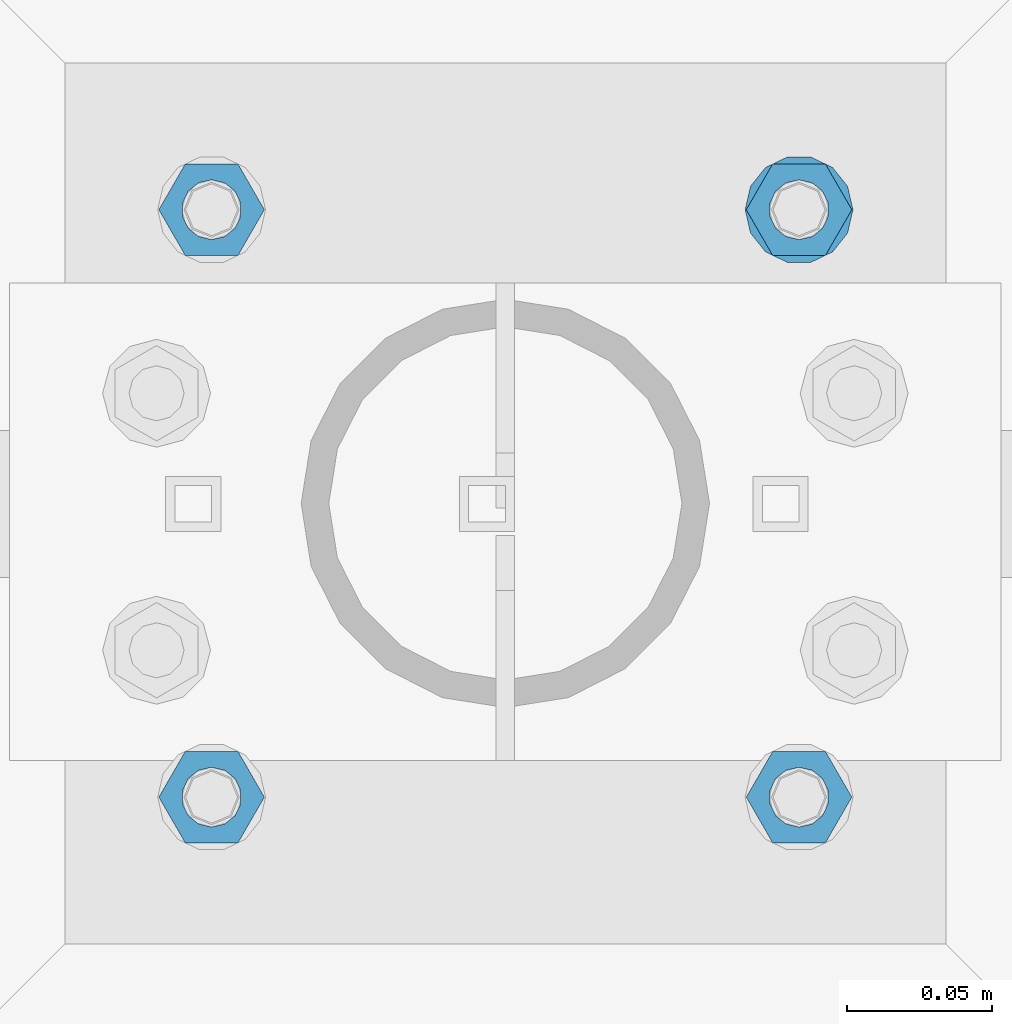
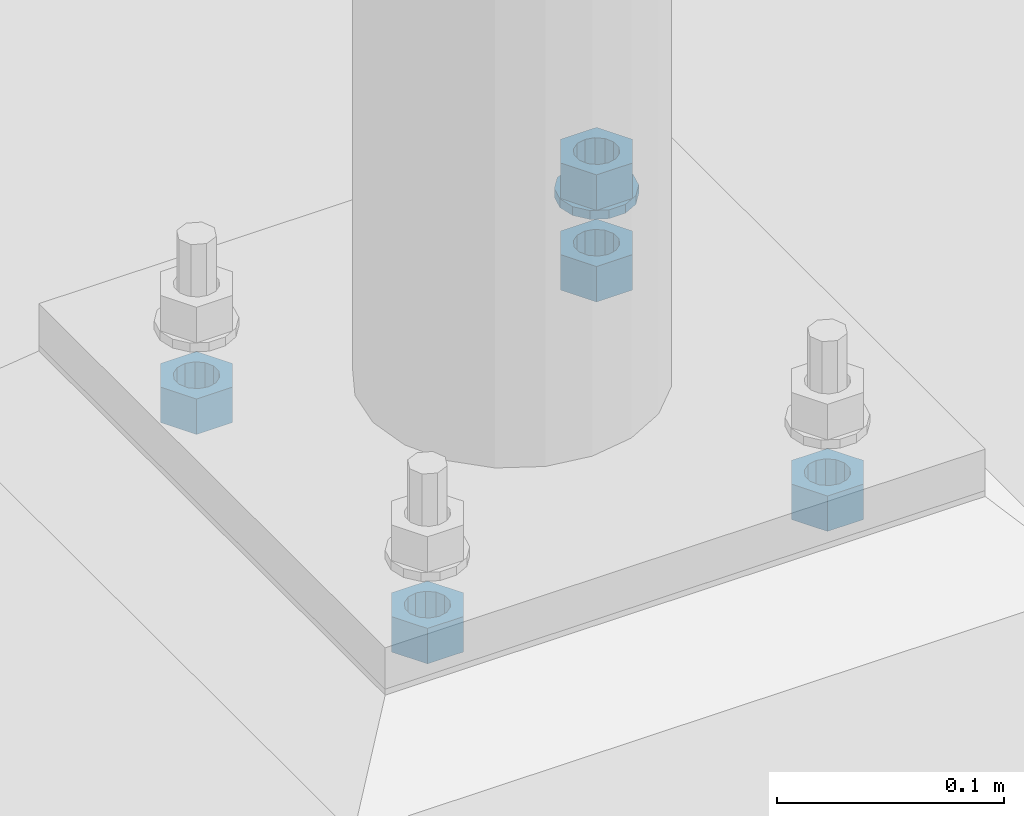
# One storey, part 619 of 975: 6 beams.
"""IFC2X3 building model written with IfcOpenShell, lengths in millimetres."""

from ifc_helpers import new_model, si_unit, frame, origin_with_axes, place, context, subcontext, project, spatial, faceted_brep, material, type_object, element, save


model = new_model("IFC2X3")

# Units and contexts
model_context = context("Model", 3, precision=1e-05, world=origin_with_axes())
body_context = subcontext(model_context, "Body", "Model", "MODEL_VIEW")
ifc_project = project(units=[si_unit("LENGTHUNIT", "METRE", prefix="MILLI"), si_unit("AREAUNIT", "SQUARE_METRE"), si_unit("VOLUMEUNIT", "CUBIC_METRE"), si_unit("MASSUNIT", "GRAM", prefix="KILO"), si_unit("TIMEUNIT", "SECOND"), si_unit("PLANEANGLEUNIT", "RADIAN"), si_unit("SOLIDANGLEUNIT", "STERADIAN"), si_unit("THERMODYNAMICTEMPERATUREUNIT", "DEGREE_CELSIUS"), si_unit("LUMINOUSINTENSITYUNIT", "LUMEN")], contexts=[model_context])

# Site, building, storey
site_placement = place(None, origin_with_axes())
site = spatial("IfcSite", under=ifc_project, at=site_placement, CompositionType="ELEMENT")
building_placement = place(site_placement, origin_with_axes())
building = spatial("IfcBuilding", under=site, at=building_placement, Name="Undefined", CompositionType="ELEMENT")
storey_placement = place(building_placement, origin_with_axes())
storey = spatial("IfcBuildingStorey", under=building, at=storey_placement, Name="Undefined", CompositionType="ELEMENT", Elevation=0.0)

# Beams
ifc_material = material(Name="STEEL/A36")
beam_type_1 = type_object("IfcBeamType", Name="3/4_WASHER", PredefinedType="NOTDEFINED")
beam_1_placement = place(storey_placement, frame((9642.47499847412, 30064.075, -236.537499999998), z_axis=(0.0, -1.0, 0.0), x_axis=(0.0, 0.0, -1.0)))
element("IfcBeam", 1, at=beam_1_placement, inside=storey, type_object=beam_type_1, material=ifc_material, Name="WASHER", ObjectType="3/4_WASHER", context=body_context, shape_type="Brep", body=[
    faceted_brep([(0.0, -18.6499996185303, 0.0), (0.0, -16.8030690426876, -8.09193156902904), (4.76250000000073, -16.8030690426876, -8.09193156902904), (4.76250000000073, -18.6499996185303, 0.0), (0.0, -11.6280845668225, -14.5811568497838), (4.76250000000073, -11.6280845668225, -14.5811568497838), (0.0, -4.15001533340001, -18.1824051902857), (4.76250000000073, -4.15001533340001, -18.1824051902857), (0.0, 4.15001533340001, -18.1824051902857), (4.76250000000073, 4.15001533340001, -18.1824051902857), (0.0, 11.6280845668234, -14.5811568497838), (4.76250000000073, 11.6280845668234, -14.5811568497838), (0.0, 16.8030690426876, -8.09193156902904), (4.76250000000073, 16.8030690426876, -8.09193156902904), (0.0, 18.6499996185303, 0.0), (4.76250000000073, 18.6499996185303, 0.0), (0.0, 16.8030690426876, 8.09193156902904), (4.76250000000073, 16.8030690426876, 8.09193156902904), (0.0, 11.6280845668225, 14.5811568497838), (4.76250000000073, 11.6280845668225, 14.5811568497838), (0.0, 4.15001533340001, 18.1824051902857), (4.76250000000073, 4.15001533340001, 18.1824051902857), (0.0, -4.15001533340001, 18.1824051902857), (4.76250000000073, -4.15001533340001, 18.1824051902857), (0.0, -11.6280845668234, 14.5811568497838), (4.76250000000073, -11.6280845668234, 14.5811568497838), (0.0, -16.8030690426876, 8.09193156902904), (4.76250000000073, -16.8030690426876, 8.09193156902904), (0.0, 0.0, 10.3199996948242), (0.0, 4.47768005528269, 9.29799844179911), (4.76250000000073, 4.47768005528269, 9.29799844179911), (4.76250000000073, 0.0, 10.3199996948242), (0.0, 8.06850066047446, 6.43441456490817), (4.76250000000073, 8.06850066047446, 6.43441456490817), (0.0, 10.0612557561917, 2.29641597052117), (4.76250000000073, 10.0612557561917, 2.29641597052117), (0.0, 10.0612557561917, -2.29641597052117), (4.76250000000073, 10.0612557561917, -2.29641597052117), (0.0, 8.06850066047446, -6.43441456490814), (4.76250000000073, 8.06850066047446, -6.43441456490814), (0.0, 4.47768005528269, -9.29799844179908), (4.76250000000073, 4.47768005528269, -9.29799844179908), (0.0, 0.0, -10.3199996948242), (4.76250000000073, 0.0, -10.3199996948242), (0.0, -4.47768005528269, -9.29799844179911), (4.76250000000073, -4.47768005528269, -9.29799844179911), (0.0, -8.06850066047446, -6.43441456490817), (4.76250000000073, -8.06850066047446, -6.43441456490817), (0.0, -10.0612557561917, -2.29641597052117), (4.76250000000073, -10.0612557561917, -2.29641597052117), (0.0, -10.0612557561917, 2.29641597052117), (4.76250000000073, -10.0612557561917, 2.29641597052117), (0.0, -8.06850066047446, 6.43441456490814), (4.76250000000073, -8.06850066047446, 6.43441456490814), (0.0, -4.47768005528269, 9.29799844179908), (4.76250000000073, -4.47768005528269, 9.29799844179908)], [[[0, 1, 2, 3]], [[1, 4, 5, 2]], [[4, 6, 7, 5]], [[6, 8, 9, 7]], [[8, 10, 11, 9]], [[10, 12, 13, 11]], [[12, 14, 15, 13]], [[14, 16, 17, 15]], [[16, 18, 19, 17]], [[18, 20, 21, 19]], [[20, 22, 23, 21]], [[22, 24, 25, 23]], [[24, 26, 27, 25]], [[26, 0, 3, 27]], [[28, 29, 30, 31]], [[29, 32, 33, 30]], [[32, 34, 35, 33]], [[34, 36, 37, 35]], [[36, 38, 39, 37]], [[38, 40, 41, 39]], [[40, 42, 43, 41]], [[42, 44, 45, 43]], [[44, 46, 47, 45]], [[46, 48, 49, 47]], [[48, 50, 51, 49]], [[50, 52, 53, 51]], [[52, 54, 55, 53]], [[54, 28, 31, 55]], [[5, 7, 9, 11, 13, 15, 17, 19, 21, 23, 25, 27, 3, 2], [33, 35, 37, 39, 41, 43, 45, 47, 49, 51, 53, 55, 31, 30]], [[26, 24, 22, 20, 18, 16, 14, 12, 10, 8, 6, 4, 1, 0], [54, 52, 50, 48, 46, 44, 42, 40, 38, 36, 34, 32, 29, 28]]]),
])
beam_type_2 = type_object("IfcBeamType", Name="3/4_HEAVY_HEX_NUT", PredefinedType="NOTDEFINED")
beam_2_placement = place(storey_placement, frame((9642.47499847412, 30064.075, -217.487499999999), z_axis=(0.0, -1.0, 0.0), x_axis=(0.0, 0.0, -1.0)))
element("IfcBeam", 2, at=beam_2_placement, inside=storey, type_object=beam_type_2, material=ifc_material, Name="NUT", ObjectType="3/4_HEAVY_HEX_NUT", context=body_context, shape_type="Brep", body=[
    faceted_brep([(0.0, -18.2600002288818, 0.0), (0.0, -9.13000011444092, -15.8100004196167), (19.0499999999993, -9.13000011444092, -15.8100004196167), (19.0499999999993, -18.2600002288818, 0.0), (0.0, 9.13000011444092, -15.8100004196167), (19.0499999999993, 9.13000011444092, -15.8100004196167), (0.0, 18.2600002288818, 0.0), (19.0499999999993, 18.2600002288818, 0.0), (0.0, 9.13000011444092, 15.8100004196167), (19.0499999999993, 9.13000011444092, 15.8100004196167), (0.0, -9.13000011444092, 15.8100004196167), (19.0499999999993, -9.13000011444092, 15.8100004196167), (0.0, 0.0, 10.3199996948242), (0.0, 4.47768005528269, 9.29799844179911), (19.0499999999993, 4.47768005528269, 9.29799844179911), (19.0499999999993, 0.0, 10.3199996948242), (0.0, 8.06850066047446, 6.43441456490817), (19.0499999999993, 8.06850066047446, 6.43441456490817), (0.0, 10.0612557561917, 2.29641597052117), (19.0499999999993, 10.0612557561917, 2.29641597052117), (0.0, 10.0612557561917, -2.29641597052117), (19.0499999999993, 10.0612557561917, -2.29641597052117), (0.0, 8.06850066047446, -6.43441456490814), (19.0499999999993, 8.06850066047446, -6.43441456490814), (0.0, 4.47768005528269, -9.29799844179908), (19.0499999999993, 4.47768005528269, -9.29799844179908), (0.0, 0.0, -10.3199996948242), (19.0499999999993, 0.0, -10.3199996948242), (0.0, -4.47768005528269, -9.29799844179911), (19.0499999999993, -4.47768005528269, -9.29799844179911), (0.0, -8.06850066047446, -6.43441456490817), (19.0499999999993, -8.06850066047446, -6.43441456490817), (0.0, -10.0612557561917, -2.29641597052117), (19.0499999999993, -10.0612557561917, -2.29641597052117), (0.0, -10.0612557561917, 2.29641597052117), (19.0499999999993, -10.0612557561917, 2.29641597052117), (0.0, -8.06850066047446, 6.43441456490814), (19.0499999999993, -8.06850066047446, 6.43441456490814), (0.0, -4.47768005528269, 9.29799844179908), (19.0499999999993, -4.47768005528269, 9.29799844179908)], [[[0, 1, 2, 3]], [[1, 4, 5, 2]], [[4, 6, 7, 5]], [[6, 8, 9, 7]], [[8, 10, 11, 9]], [[10, 0, 3, 11]], [[12, 13, 14, 15]], [[13, 16, 17, 14]], [[16, 18, 19, 17]], [[18, 20, 21, 19]], [[20, 22, 23, 21]], [[22, 24, 25, 23]], [[24, 26, 27, 25]], [[26, 28, 29, 27]], [[28, 30, 31, 29]], [[30, 32, 33, 31]], [[32, 34, 35, 33]], [[34, 36, 37, 35]], [[36, 38, 39, 37]], [[38, 12, 15, 39]], [[5, 7, 9, 11, 3, 2], [17, 19, 21, 23, 25, 27, 29, 31, 33, 35, 37, 39, 15, 14]], [[10, 8, 6, 4, 1, 0], [38, 36, 34, 32, 30, 28, 26, 24, 22, 20, 18, 16, 13, 12]]]),
])
beam_3_placement = place(storey_placement, frame((9439.27500152588, 29860.8750030518, -266.7), z_axis=(0.0, -1.0, 0.0), x_axis=(0.0, 0.0, -1.0)))
element("IfcBeam", 3, at=beam_3_placement, inside=storey, type_object=beam_type_2, material=ifc_material, Name="NUT", ObjectType="3/4_HEAVY_HEX_NUT", context=body_context, shape_type="Brep", body=[
    faceted_brep([(0.0, -18.2600002288818, 0.0), (0.0, -9.13000011444092, -15.8100004196167), (19.0499999999993, -9.13000011444092, -15.8100004196167), (19.0499999999993, -18.2600002288818, 0.0), (0.0, 9.13000011444092, -15.8100004196167), (19.0499999999993, 9.13000011444092, -15.8100004196167), (0.0, 18.2600002288818, 0.0), (19.0499999999993, 18.2600002288818, 0.0), (0.0, 9.13000011444092, 15.8100004196167), (19.0499999999993, 9.13000011444092, 15.8100004196167), (0.0, -9.13000011444092, 15.8100004196167), (19.0499999999993, -9.13000011444092, 15.8100004196167), (0.0, 0.0, 10.3199996948242), (0.0, 4.47768005528269, 9.29799844179911), (19.0499999999993, 4.47768005528269, 9.29799844179911), (19.0499999999993, 0.0, 10.3199996948242), (0.0, 8.06850066047446, 6.43441456490817), (19.0499999999993, 8.06850066047446, 6.43441456490817), (0.0, 10.0612557561917, 2.29641597052117), (19.0499999999993, 10.0612557561917, 2.29641597052117), (0.0, 10.0612557561917, -2.29641597052117), (19.0499999999993, 10.0612557561917, -2.29641597052117), (0.0, 8.06850066047446, -6.43441456490814), (19.0499999999993, 8.06850066047446, -6.43441456490814), (0.0, 4.47768005528269, -9.29799844179908), (19.0499999999993, 4.47768005528269, -9.29799844179908), (0.0, 0.0, -10.3199996948242), (19.0499999999993, 0.0, -10.3199996948242), (0.0, -4.47768005528269, -9.29799844179911), (19.0499999999993, -4.47768005528269, -9.29799844179911), (0.0, -8.06850066047446, -6.43441456490817), (19.0499999999993, -8.06850066047446, -6.43441456490817), (0.0, -10.0612557561917, -2.29641597052117), (19.0499999999993, -10.0612557561917, -2.29641597052117), (0.0, -10.0612557561917, 2.29641597052117), (19.0499999999993, -10.0612557561917, 2.29641597052117), (0.0, -8.06850066047446, 6.43441456490814), (19.0499999999993, -8.06850066047446, 6.43441456490814), (0.0, -4.47768005528269, 9.29799844179908), (19.0499999999993, -4.47768005528269, 9.29799844179908)], [[[0, 1, 2, 3]], [[1, 4, 5, 2]], [[4, 6, 7, 5]], [[6, 8, 9, 7]], [[8, 10, 11, 9]], [[10, 0, 3, 11]], [[12, 13, 14, 15]], [[13, 16, 17, 14]], [[16, 18, 19, 17]], [[18, 20, 21, 19]], [[20, 22, 23, 21]], [[22, 24, 25, 23]], [[24, 26, 27, 25]], [[26, 28, 29, 27]], [[28, 30, 31, 29]], [[30, 32, 33, 31]], [[32, 34, 35, 33]], [[34, 36, 37, 35]], [[36, 38, 39, 37]], [[38, 12, 15, 39]], [[5, 7, 9, 11, 3, 2], [17, 19, 21, 23, 25, 27, 29, 31, 33, 35, 37, 39, 15, 14]], [[10, 8, 6, 4, 1, 0], [38, 36, 34, 32, 30, 28, 26, 24, 22, 20, 18, 16, 13, 12]]]),
])
beam_4_placement = place(storey_placement, frame((9642.47499847412, 29860.8750030518, -266.7), z_axis=(0.0, -1.0, 0.0), x_axis=(0.0, 0.0, -1.0)))
element("IfcBeam", 4, at=beam_4_placement, inside=storey, type_object=beam_type_2, material=ifc_material, Name="NUT", ObjectType="3/4_HEAVY_HEX_NUT", context=body_context, shape_type="Brep", body=[
    faceted_brep([(0.0, -18.2600002288818, 0.0), (0.0, -9.13000011444092, -15.8100004196167), (19.0499999999993, -9.13000011444092, -15.8100004196167), (19.0499999999993, -18.2600002288818, 0.0), (0.0, 9.13000011444092, -15.8100004196167), (19.0499999999993, 9.13000011444092, -15.8100004196167), (0.0, 18.2600002288818, 0.0), (19.0499999999993, 18.2600002288818, 0.0), (0.0, 9.13000011444092, 15.8100004196167), (19.0499999999993, 9.13000011444092, 15.8100004196167), (0.0, -9.13000011444092, 15.8100004196167), (19.0499999999993, -9.13000011444092, 15.8100004196167), (0.0, 0.0, 10.3199996948242), (0.0, 4.47768005528269, 9.29799844179911), (19.0499999999993, 4.47768005528269, 9.29799844179911), (19.0499999999993, 0.0, 10.3199996948242), (0.0, 8.06850066047446, 6.43441456490817), (19.0499999999993, 8.06850066047446, 6.43441456490817), (0.0, 10.0612557561917, 2.29641597052117), (19.0499999999993, 10.0612557561917, 2.29641597052117), (0.0, 10.0612557561917, -2.29641597052117), (19.0499999999993, 10.0612557561917, -2.29641597052117), (0.0, 8.06850066047446, -6.43441456490814), (19.0499999999993, 8.06850066047446, -6.43441456490814), (0.0, 4.47768005528269, -9.29799844179908), (19.0499999999993, 4.47768005528269, -9.29799844179908), (0.0, 0.0, -10.3199996948242), (19.0499999999993, 0.0, -10.3199996948242), (0.0, -4.47768005528269, -9.29799844179911), (19.0499999999993, -4.47768005528269, -9.29799844179911), (0.0, -8.06850066047446, -6.43441456490817), (19.0499999999993, -8.06850066047446, -6.43441456490817), (0.0, -10.0612557561917, -2.29641597052117), (19.0499999999993, -10.0612557561917, -2.29641597052117), (0.0, -10.0612557561917, 2.29641597052117), (19.0499999999993, -10.0612557561917, 2.29641597052117), (0.0, -8.06850066047446, 6.43441456490814), (19.0499999999993, -8.06850066047446, 6.43441456490814), (0.0, -4.47768005528269, 9.29799844179908), (19.0499999999993, -4.47768005528269, 9.29799844179908)], [[[0, 1, 2, 3]], [[1, 4, 5, 2]], [[4, 6, 7, 5]], [[6, 8, 9, 7]], [[8, 10, 11, 9]], [[10, 0, 3, 11]], [[12, 13, 14, 15]], [[13, 16, 17, 14]], [[16, 18, 19, 17]], [[18, 20, 21, 19]], [[20, 22, 23, 21]], [[22, 24, 25, 23]], [[24, 26, 27, 25]], [[26, 28, 29, 27]], [[28, 30, 31, 29]], [[30, 32, 33, 31]], [[32, 34, 35, 33]], [[34, 36, 37, 35]], [[36, 38, 39, 37]], [[38, 12, 15, 39]], [[5, 7, 9, 11, 3, 2], [17, 19, 21, 23, 25, 27, 29, 31, 33, 35, 37, 39, 15, 14]], [[10, 8, 6, 4, 1, 0], [38, 36, 34, 32, 30, 28, 26, 24, 22, 20, 18, 16, 13, 12]]]),
])
beam_5_placement = place(storey_placement, frame((9439.27500152588, 30064.075, -266.7), z_axis=(0.0, -1.0, 0.0), x_axis=(0.0, 0.0, -1.0)))
element("IfcBeam", 5, at=beam_5_placement, inside=storey, type_object=beam_type_2, material=ifc_material, Name="NUT", ObjectType="3/4_HEAVY_HEX_NUT", context=body_context, shape_type="Brep", body=[
    faceted_brep([(0.0, -18.2600002288818, 0.0), (0.0, -9.13000011444092, -15.8100004196167), (19.0499999999993, -9.13000011444092, -15.8100004196167), (19.0499999999993, -18.2600002288818, 0.0), (0.0, 9.13000011444092, -15.8100004196167), (19.0499999999993, 9.13000011444092, -15.8100004196167), (0.0, 18.2600002288818, 0.0), (19.0499999999993, 18.2600002288818, 0.0), (0.0, 9.13000011444092, 15.8100004196167), (19.0499999999993, 9.13000011444092, 15.8100004196167), (0.0, -9.13000011444092, 15.8100004196167), (19.0499999999993, -9.13000011444092, 15.8100004196167), (0.0, 0.0, 10.3199996948242), (0.0, 4.47768005528269, 9.29799844179911), (19.0499999999993, 4.47768005528269, 9.29799844179911), (19.0499999999993, 0.0, 10.3199996948242), (0.0, 8.06850066047446, 6.43441456490817), (19.0499999999993, 8.06850066047446, 6.43441456490817), (0.0, 10.0612557561917, 2.29641597052117), (19.0499999999993, 10.0612557561917, 2.29641597052117), (0.0, 10.0612557561917, -2.29641597052117), (19.0499999999993, 10.0612557561917, -2.29641597052117), (0.0, 8.06850066047446, -6.43441456490814), (19.0499999999993, 8.06850066047446, -6.43441456490814), (0.0, 4.47768005528269, -9.29799844179908), (19.0499999999993, 4.47768005528269, -9.29799844179908), (0.0, 0.0, -10.3199996948242), (19.0499999999993, 0.0, -10.3199996948242), (0.0, -4.47768005528269, -9.29799844179911), (19.0499999999993, -4.47768005528269, -9.29799844179911), (0.0, -8.06850066047446, -6.43441456490817), (19.0499999999993, -8.06850066047446, -6.43441456490817), (0.0, -10.0612557561917, -2.29641597052117), (19.0499999999993, -10.0612557561917, -2.29641597052117), (0.0, -10.0612557561917, 2.29641597052117), (19.0499999999993, -10.0612557561917, 2.29641597052117), (0.0, -8.06850066047446, 6.43441456490814), (19.0499999999993, -8.06850066047446, 6.43441456490814), (0.0, -4.47768005528269, 9.29799844179908), (19.0499999999993, -4.47768005528269, 9.29799844179908)], [[[0, 1, 2, 3]], [[1, 4, 5, 2]], [[4, 6, 7, 5]], [[6, 8, 9, 7]], [[8, 10, 11, 9]], [[10, 0, 3, 11]], [[12, 13, 14, 15]], [[13, 16, 17, 14]], [[16, 18, 19, 17]], [[18, 20, 21, 19]], [[20, 22, 23, 21]], [[22, 24, 25, 23]], [[24, 26, 27, 25]], [[26, 28, 29, 27]], [[28, 30, 31, 29]], [[30, 32, 33, 31]], [[32, 34, 35, 33]], [[34, 36, 37, 35]], [[36, 38, 39, 37]], [[38, 12, 15, 39]], [[5, 7, 9, 11, 3, 2], [17, 19, 21, 23, 25, 27, 29, 31, 33, 35, 37, 39, 15, 14]], [[10, 8, 6, 4, 1, 0], [38, 36, 34, 32, 30, 28, 26, 24, 22, 20, 18, 16, 13, 12]]]),
])
beam_6_placement = place(storey_placement, frame((9642.47499847412, 30064.075, -266.7), z_axis=(0.0, -1.0, 0.0), x_axis=(0.0, 0.0, -1.0)))
element("IfcBeam", 6, at=beam_6_placement, inside=storey, type_object=beam_type_2, material=ifc_material, Name="NUT", ObjectType="3/4_HEAVY_HEX_NUT", context=body_context, shape_type="Brep", body=[
    faceted_brep([(0.0, -18.2600002288818, 0.0), (0.0, -9.13000011444092, -15.8100004196167), (19.0499999999993, -9.13000011444092, -15.8100004196167), (19.0499999999993, -18.2600002288818, 0.0), (0.0, 9.13000011444092, -15.8100004196167), (19.0499999999993, 9.13000011444092, -15.8100004196167), (0.0, 18.2600002288818, 0.0), (19.0499999999993, 18.2600002288818, 0.0), (0.0, 9.13000011444092, 15.8100004196167), (19.0499999999993, 9.13000011444092, 15.8100004196167), (0.0, -9.13000011444092, 15.8100004196167), (19.0499999999993, -9.13000011444092, 15.8100004196167), (0.0, 0.0, 10.3199996948242), (0.0, 4.47768005528269, 9.29799844179911), (19.0499999999993, 4.47768005528269, 9.29799844179911), (19.0499999999993, 0.0, 10.3199996948242), (0.0, 8.06850066047446, 6.43441456490817), (19.0499999999993, 8.06850066047446, 6.43441456490817), (0.0, 10.0612557561917, 2.29641597052117), (19.0499999999993, 10.0612557561917, 2.29641597052117), (0.0, 10.0612557561917, -2.29641597052117), (19.0499999999993, 10.0612557561917, -2.29641597052117), (0.0, 8.06850066047446, -6.43441456490814), (19.0499999999993, 8.06850066047446, -6.43441456490814), (0.0, 4.47768005528269, -9.29799844179908), (19.0499999999993, 4.47768005528269, -9.29799844179908), (0.0, 0.0, -10.3199996948242), (19.0499999999993, 0.0, -10.3199996948242), (0.0, -4.47768005528269, -9.29799844179911), (19.0499999999993, -4.47768005528269, -9.29799844179911), (0.0, -8.06850066047446, -6.43441456490817), (19.0499999999993, -8.06850066047446, -6.43441456490817), (0.0, -10.0612557561917, -2.29641597052117), (19.0499999999993, -10.0612557561917, -2.29641597052117), (0.0, -10.0612557561917, 2.29641597052117), (19.0499999999993, -10.0612557561917, 2.29641597052117), (0.0, -8.06850066047446, 6.43441456490814), (19.0499999999993, -8.06850066047446, 6.43441456490814), (0.0, -4.47768005528269, 9.29799844179908), (19.0499999999993, -4.47768005528269, 9.29799844179908)], [[[0, 1, 2, 3]], [[1, 4, 5, 2]], [[4, 6, 7, 5]], [[6, 8, 9, 7]], [[8, 10, 11, 9]], [[10, 0, 3, 11]], [[12, 13, 14, 15]], [[13, 16, 17, 14]], [[16, 18, 19, 17]], [[18, 20, 21, 19]], [[20, 22, 23, 21]], [[22, 24, 25, 23]], [[24, 26, 27, 25]], [[26, 28, 29, 27]], [[28, 30, 31, 29]], [[30, 32, 33, 31]], [[32, 34, 35, 33]], [[34, 36, 37, 35]], [[36, 38, 39, 37]], [[38, 12, 15, 39]], [[5, 7, 9, 11, 3, 2], [17, 19, 21, 23, 25, 27, 29, 31, 33, 35, 37, 39, 15, 14]], [[10, 8, 6, 4, 1, 0], [38, 36, 34, 32, 30, 28, 26, 24, 22, 20, 18, 16, 13, 12]]]),
])

save(model, "model.ifc")
